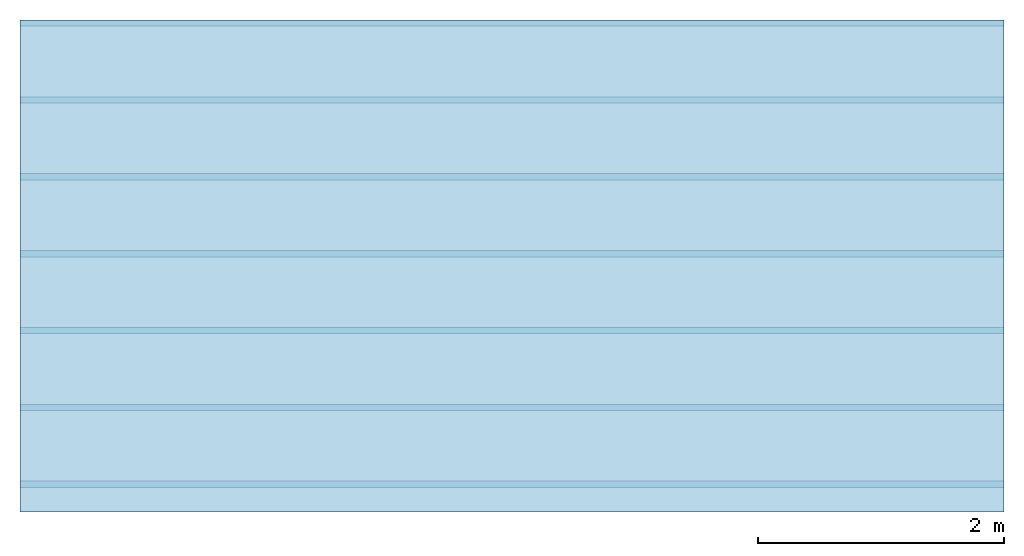
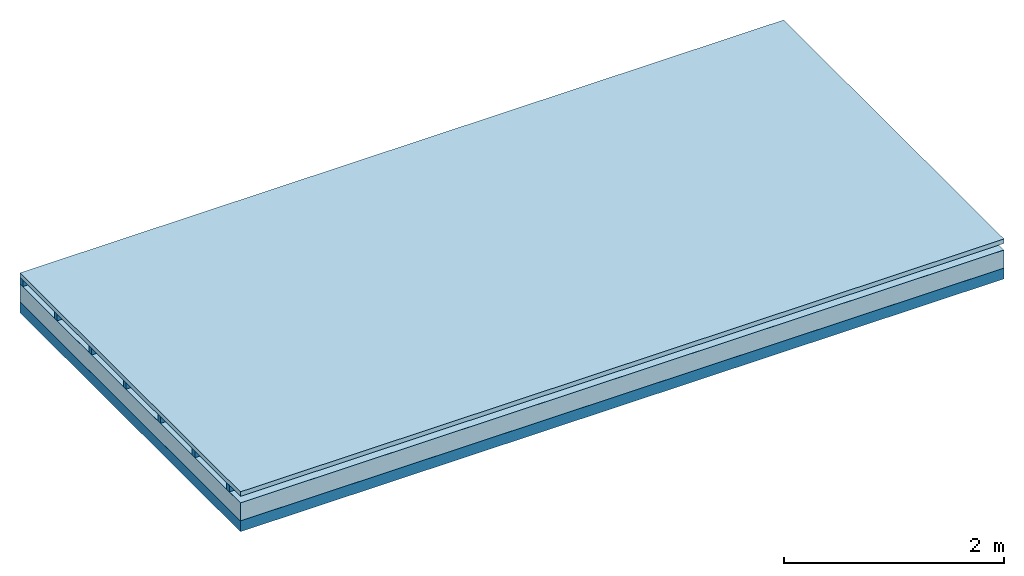
# One storey: 4 plates, 2 members, 1 element without a shape of its own.
"""IFC4 building model written with IfcOpenShell, lengths in metres."""

from ifc_helpers import new_model, si_unit, derived_unit, direction, frame, frame_2d, origin, origin_with_axes, place, context, project, spatial, rectangle, extrude, material, layer, layer_set, type_object, element, aggregate, save


model = new_model("IFC4")

# Units and contexts
plan_context = context("Plan", 3, precision=1e-05, world=origin(), true_north=direction((0.0, 1.0)))
model_context = context("Model", 3, precision=1e-05, world=origin(), true_north=direction((0.0, 1.0)))
ifc_project = project(units=[si_unit("LENGTHUNIT", "METRE"), derived_unit("SOUNDPRESSUREUNIT", [(si_unit("PRESSUREUNIT", "PASCAL", prefix="MICRO"), 0)]), si_unit("ENERGYUNIT", "JOULE", prefix="MEGA"), si_unit("MASSUNIT", "GRAM", prefix="KILO"), derived_unit("THERMALTRANSMITTANCEUNIT", [(si_unit("POWERUNIT", "WATT"), 1), (si_unit("AREAUNIT", "SQUARE_METRE"), -1), (si_unit("THERMODYNAMICTEMPERATUREUNIT", "KELVIN"), -1)]), derived_unit("AREADENSITYUNIT", [(si_unit("MASSUNIT", "GRAM", prefix="KILO"), 1), (si_unit("AREAUNIT", "SQUARE_METRE"), -1)]), derived_unit("USERDEFINED", [(si_unit("ENERGYUNIT", "JOULE", prefix="MEGA"), 1), (si_unit("AREAUNIT", "SQUARE_METRE"), -1)])], contexts=[plan_context, model_context])

# Site, building, storey
site = spatial("IfcSite", under=ifc_project)
building_placement = place(None, origin())
building = spatial("IfcBuilding", under=site, at=building_placement)
storey_placement = place(building_placement, origin())
storey = spatial("IfcBuildingStorey", under=building, at=storey_placement)

# Slab, members, plates
ifc_material_1 = material(Name="Roof tiles", Category="03.015")
ifc_layer_1 = layer(ifc_material_1, 0.05, Name="Roofing")
ifc_layer_2 = layer(None, 0.072, Name="Battens / profiles")
ifc_material_2 = material(Name="Roofing underlay", Category="09.008")
ifc_layer_3 = layer(ifc_material_2, 0.00018, Name="Under the roof")
ifc_material_3 = material(Category="10.009")
ifc_layer_4 = layer(ifc_material_3, 0.2, Name="Exterior insulation layer 1")
ifc_material_4 = material(Name="Vapor barrier polyethylene (PE)", Category="09.002")
ifc_layer_5 = layer(ifc_material_4, 0.00018, Name="above 1st layer")
ifc_material_5 = material(Name="of the art")
ifc_layer_6 = layer(ifc_material_5, 0.0, Name="Bond")
ifc_layer_7 = layer(None, 0.12, Name="Supporting structure")
ifc_layer_set = layer_set([ifc_layer_1, ifc_layer_2, ifc_layer_3, ifc_layer_4, ifc_layer_5, ifc_layer_6, ifc_layer_7])
slab_type = type_object("IfcSlabType", Name="E0159", PredefinedType="NOTDEFINED", material=ifc_layer_set)
slab_placement = place(None, frame((0.0, 0.0, 0.0), z_axis=(0.0, 0.0, -1.0), x_axis=(1.0, 0.0, 0.0)))
slab = element("IfcSlab", 1, at=slab_placement, inside=storey, type_object=slab_type, material=ifc_layer_set, Name="Slab #1")
ifc_material_6 = material()
member_1_placement = place(slab_placement, origin())
member_1 = element("IfcMember", 2, at=member_1_placement, material=ifc_material_6, Name="Battens / profiles", context=plan_context, shape_type="SweptSolid", body=[
    extrude(rectangle(XDim=0.05, YDim=0.072, at=frame_2d((0.025, 0.036), x_axis=(1.0, 0.0))), frame((0.0, 0.0, 0.05), z_axis=(1.0, 0.0, 0.0), x_axis=(0.0, 1.0, 0.0)), (0.0, 0.0, 1.0), 8.0),
    extrude(rectangle(XDim=0.05, YDim=0.072, at=frame_2d((0.025, 0.036), x_axis=(1.0, 0.0))), frame((0.0, 0.625, 0.05), z_axis=(1.0, 0.0, 0.0), x_axis=(0.0, 1.0, 0.0)), (0.0, 0.0, 1.0), 8.0),
    extrude(rectangle(XDim=0.05, YDim=0.072, at=frame_2d((0.025, 0.036), x_axis=(1.0, 0.0))), frame((0.0, 1.25, 0.05), z_axis=(1.0, 0.0, 0.0), x_axis=(0.0, 1.0, 0.0)), (0.0, 0.0, 1.0), 8.0),
    extrude(rectangle(XDim=0.05, YDim=0.072, at=frame_2d((0.025, 0.036), x_axis=(1.0, 0.0))), frame((0.0, 1.875, 0.05), z_axis=(1.0, 0.0, 0.0), x_axis=(0.0, 1.0, 0.0)), (0.0, 0.0, 1.0), 8.0),
    extrude(rectangle(XDim=0.05, YDim=0.072, at=frame_2d((0.025, 0.036), x_axis=(1.0, 0.0))), frame((0.0, 2.5, 0.05), z_axis=(1.0, 0.0, 0.0), x_axis=(0.0, 1.0, 0.0)), (0.0, 0.0, 1.0), 8.0),
    extrude(rectangle(XDim=0.05, YDim=0.072, at=frame_2d((0.025, 0.036), x_axis=(1.0, 0.0))), frame((0.0, 3.125, 0.05), z_axis=(1.0, 0.0, 0.0), x_axis=(0.0, 1.0, 0.0)), (0.0, 0.0, 1.0), 8.0),
    extrude(rectangle(XDim=0.05, YDim=0.072, at=frame_2d((0.025, 0.036), x_axis=(1.0, 0.0))), frame((0.0, 3.75, 0.05), z_axis=(1.0, 0.0, 0.0), x_axis=(0.0, 1.0, 0.0)), (0.0, 0.0, 1.0), 8.0),
])
ifc_material_7 = material(Name="Solid timber panel")
member_2_placement = place(slab_placement, origin())
member_2 = element("IfcMember", 3, at=member_2_placement, material=ifc_material_7, Name="Supporting structure", context=plan_context, shape_type="SweptSolid", body=[
    extrude(rectangle(XDim=1.0, YDim=0.12, at=frame_2d((0.5, 0.06), x_axis=(1.0, 0.0))), frame((0.0, 4.0, 0.32236), z_axis=(0.0, -1.0, 0.0), x_axis=(1.0, 0.0, 0.0)), (0.0, 0.0, 1.0), 4.0),
    extrude(rectangle(XDim=1.0, YDim=0.12, at=frame_2d((0.5, 0.06), x_axis=(1.0, 0.0))), frame((1.0, 4.0, 0.32236), z_axis=(0.0, -1.0, 0.0), x_axis=(1.0, 0.0, 0.0)), (0.0, 0.0, 1.0), 4.0),
    extrude(rectangle(XDim=1.0, YDim=0.12, at=frame_2d((0.5, 0.06), x_axis=(1.0, 0.0))), frame((2.0, 4.0, 0.32236), z_axis=(0.0, -1.0, 0.0), x_axis=(1.0, 0.0, 0.0)), (0.0, 0.0, 1.0), 4.0),
    extrude(rectangle(XDim=1.0, YDim=0.12, at=frame_2d((0.5, 0.06), x_axis=(1.0, 0.0))), frame((3.0, 4.0, 0.32236), z_axis=(0.0, -1.0, 0.0), x_axis=(1.0, 0.0, 0.0)), (0.0, 0.0, 1.0), 4.0),
    extrude(rectangle(XDim=1.0, YDim=0.12, at=frame_2d((0.5, 0.06), x_axis=(1.0, 0.0))), frame((4.0, 4.0, 0.32236), z_axis=(0.0, -1.0, 0.0), x_axis=(1.0, 0.0, 0.0)), (0.0, 0.0, 1.0), 4.0),
    extrude(rectangle(XDim=1.0, YDim=0.12, at=frame_2d((0.5, 0.06), x_axis=(1.0, 0.0))), frame((5.0, 4.0, 0.32236), z_axis=(0.0, -1.0, 0.0), x_axis=(1.0, 0.0, 0.0)), (0.0, 0.0, 1.0), 4.0),
    extrude(rectangle(XDim=1.0, YDim=0.12, at=frame_2d((0.5, 0.06), x_axis=(1.0, 0.0))), frame((6.0, 4.0, 0.32236), z_axis=(0.0, -1.0, 0.0), x_axis=(1.0, 0.0, 0.0)), (0.0, 0.0, 1.0), 4.0),
    extrude(rectangle(XDim=1.0, YDim=0.12, at=frame_2d((0.5, 0.06), x_axis=(1.0, 0.0))), frame((7.0, 4.0, 0.32236), z_axis=(0.0, -1.0, 0.0), x_axis=(1.0, 0.0, 0.0)), (0.0, 0.0, 1.0), 4.0),
])
plate_1_placement = place(slab_placement, origin())
plate_1 = element("IfcPlate", 4, at=plate_1_placement, material=ifc_material_1, Name="Roofing", context=plan_context, shape_type="SweptSolid", body=[
    extrude(rectangle(XDim=8.0, YDim=4.0, at=frame_2d((4.0, 2.0), x_axis=(1.0, 0.0))), origin_with_axes(), (0.0, 0.0, 1.0), 0.05),
])
plate_2_placement = place(slab_placement, origin())
plate_2 = element("IfcPlate", 5, at=plate_2_placement, material=ifc_material_2, Name="Under the roof", context=plan_context, shape_type="SweptSolid", body=[
    extrude(rectangle(XDim=8.0, YDim=4.0, at=frame_2d((4.0, 2.0), x_axis=(1.0, 0.0))), frame((0.0, 0.0, 0.122), z_axis=(0.0, 0.0, 1.0), x_axis=(1.0, 0.0, 0.0)), (0.0, 0.0, 1.0), 0.00018),
])
plate_3_placement = place(slab_placement, origin())
plate_3 = element("IfcPlate", 6, at=plate_3_placement, material=ifc_material_3, Name="Exterior insulation layer 1", context=plan_context, shape_type="SweptSolid", body=[
    extrude(rectangle(XDim=8.0, YDim=4.0, at=frame_2d((4.0, 2.0), x_axis=(1.0, 0.0))), frame((0.0, 0.0, 0.12218), z_axis=(0.0, 0.0, 1.0), x_axis=(1.0, 0.0, 0.0)), (0.0, 0.0, 1.0), 0.2),
])
plate_4_placement = place(slab_placement, origin())
plate_4 = element("IfcPlate", 7, at=plate_4_placement, material=ifc_material_4, Name="above 1st layer", context=plan_context, shape_type="SweptSolid", body=[
    extrude(rectangle(XDim=8.0, YDim=4.0, at=frame_2d((4.0, 2.0), x_axis=(1.0, 0.0))), frame((0.0, 0.0, 0.32218), z_axis=(0.0, 0.0, 1.0), x_axis=(1.0, 0.0, 0.0)), (0.0, 0.0, 1.0), 0.00018),
])
aggregate(slab, [plate_1, member_1, plate_2, plate_3, plate_4, member_2])

save(model, "model.ifc")
